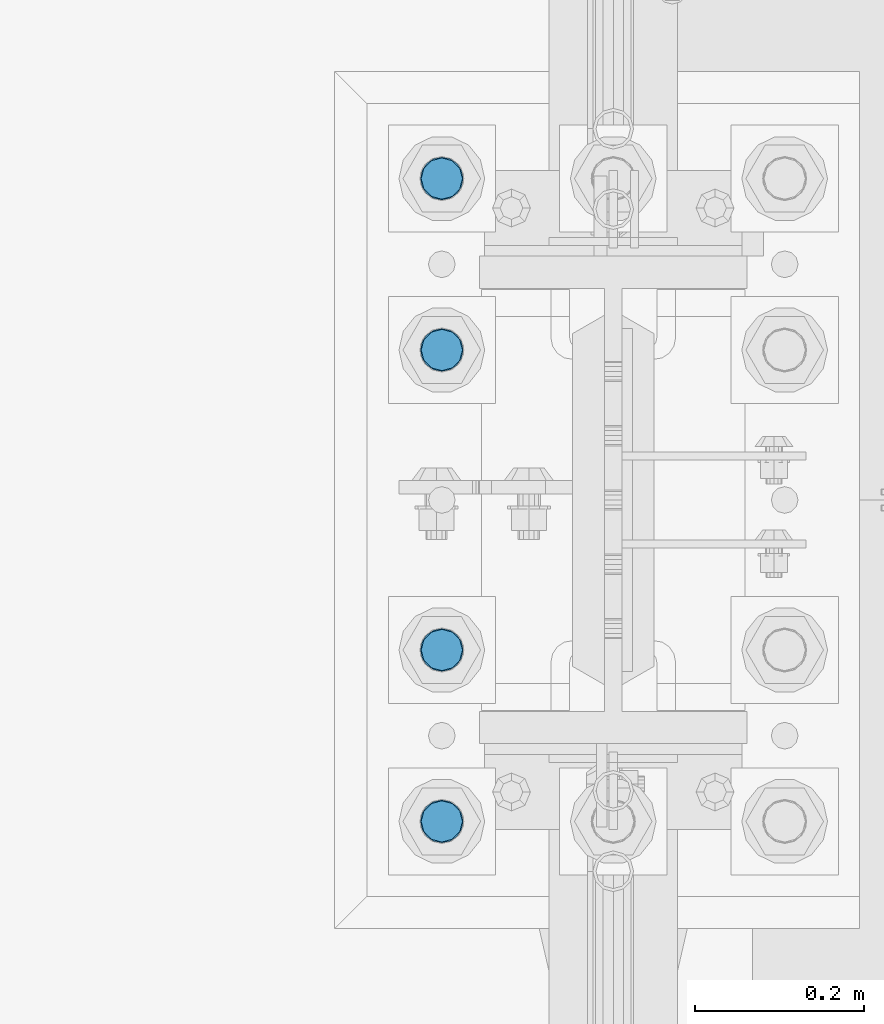
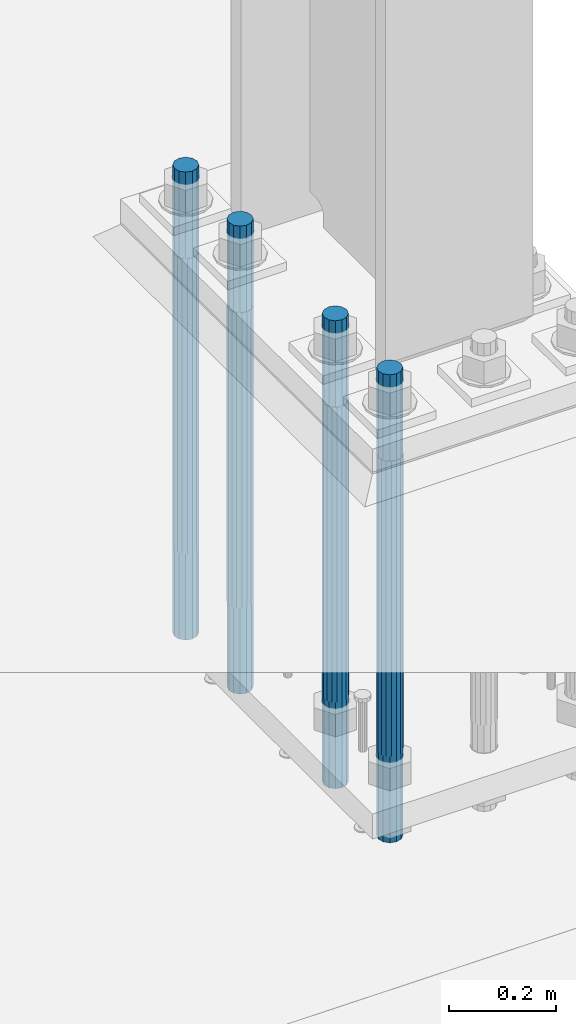
# One storey, part 738 of 1876: 4 columns, 1 element without a shape of its own.
"""IFC2X3 building model written with IfcOpenShell, lengths in millimetres."""

from ifc_helpers import new_model, si_unit, frame, origin_with_axes, place, context, subcontext, project, spatial, faceted_brep, material, type_object, element, aggregate, save


model = new_model("IFC2X3")

# Units and contexts
model_context = context("Model", 3, precision=1e-05, world=origin_with_axes())
body_context = subcontext(model_context, "Body", "Model", "MODEL_VIEW")
ifc_project = project(units=[si_unit("LENGTHUNIT", "METRE", prefix="MILLI"), si_unit("AREAUNIT", "SQUARE_METRE"), si_unit("VOLUMEUNIT", "CUBIC_METRE"), si_unit("MASSUNIT", "GRAM", prefix="KILO"), si_unit("TIMEUNIT", "SECOND"), si_unit("PLANEANGLEUNIT", "RADIAN"), si_unit("SOLIDANGLEUNIT", "STERADIAN"), si_unit("THERMODYNAMICTEMPERATUREUNIT", "DEGREE_CELSIUS"), si_unit("LUMINOUSINTENSITYUNIT", "LUMEN")], contexts=[model_context])

# Site, building, storey
site_placement = place(None, origin_with_axes())
site = spatial("IfcSite", under=ifc_project, at=site_placement, CompositionType="ELEMENT")
building_placement = place(site_placement, origin_with_axes())
building = spatial("IfcBuilding", under=site, at=building_placement, Name="Undefined", CompositionType="ELEMENT")
storey_placement = place(building_placement, origin_with_axes())
storey = spatial("IfcBuildingStorey", under=building, at=storey_placement, Name="Undefined", CompositionType="ELEMENT", Elevation=0.0)

# Assembly, columns
assembly_placement = place(storey_placement, origin_with_axes())
assembly = element("IfcElementAssembly", 1, at=assembly_placement, inside=storey, Name="TEMPLATE", AssemblyPlace="NOTDEFINED", PredefinedType="RIGID_FRAME")
ifc_material = material(Name="STEEL/F1554-GR.105")
column_type = type_object("IfcColumnType", PredefinedType="NOTDEFINED")
column_1_placement = place(assembly_placement, frame((7416.8, 7239.0, 0.0), z_axis=(0.0, -1.0, 0.0), x_axis=(0.0, 0.0, -1.0)))
column_1 = element("IfcColumn", 2, at=column_1_placement, type_object=column_type, material=ifc_material, Name="ANCHOR_BOLTS", context=body_context, shape_type="Brep", body=[
    faceted_brep([(-196.85, -21.217622392719, 12.25), (-196.85, -12.25, 21.2176223927188), (-196.85, 0.0, 24.5), (-196.85, 12.25, 21.2176223927188), (-196.85, 21.217622392719, 12.25), (-196.85, 24.5, 0.0), (-196.85, 21.217622392719, -12.25), (-196.85, 12.25, -21.2176223927188), (-196.85, 0.0, -24.5), (-196.85, -12.25, -21.2176223927188), (-196.85, -21.217622392719, -12.25), (-196.85, -24.5, 0.0), (0.0, 24.5, 0.0), (0.0, 21.217622392719, -12.25), (0.0, 12.25, -21.2176223927188), (0.0, 0.0, -24.5), (0.0, -12.25, -21.2176223927188), (0.0, -21.217622392719, -12.25), (0.0, -24.5, 0.0), (0.0, -21.217622392719, 12.25), (0.0, -12.25, 21.2176223927188), (0.0, 0.0, 24.5), (0.0, 12.25, 21.2176223927188), (0.0, 21.217622392719, 12.25), (0.0, -23.4665401257871, 9.7201591820733), (0.0, -17.9605122421381, 17.9605122421383), (0.0, -9.72015918207308, 23.4665401257867), (0.0, 0.0, 25.4000000000001), (0.0, 9.72015918207308, 23.4665401257867), (0.0, 17.9605122421381, 17.9605122421383), (0.0, 23.4665401257871, 9.7201591820733), (0.0, 25.3999996185339, 9.09494701772928e-13), (0.0, 23.4665401257871, -9.7201591820733), (0.0, 17.9605122421381, -17.9605122421383), (0.0, 9.72015918207308, -23.4665401257867), (0.0, 0.0, -25.4000000000001), (0.0, -9.72015918207308, -23.4665401257867), (0.0, -17.9605122421381, -17.9605122421383), (0.0, -23.4665401257871, -9.7201591820733), (0.0, -25.3999996185375, 0.0), (673.1, -25.3999999999996, 0.0), (673.1, -23.4665401257871, 9.7201591820733), (673.1, -17.9605122421381, 17.9605122421383), (673.1, -9.72015918207308, 23.4665401257867), (673.1, 0.0, 25.4000000000001), (673.1, 9.72015918207308, 23.4665401257867), (673.1, 17.9605122421381, 17.9605122421383), (673.1, 23.4665401257871, 9.7201591820733), (673.1, 25.3999999999996, 0.0), (673.1, 23.4665401257871, -9.7201591820733), (673.1, 17.9605122421381, -17.9605122421383), (673.1, 9.72015918207308, -23.4665401257867), (673.1, 0.0, -25.4000000000001), (673.1, -9.72015918207308, -23.4665401257867), (673.1, -17.9605122421381, -17.9605122421383), (673.1, -23.4665401257871, -9.7201591820733), (673.1, -12.25, 21.2176223927188), (673.1, 0.0, 24.5), (673.1, 12.25, 21.2176223927188), (673.1, 21.217622392719, 12.25), (673.1, 24.5, 0.0), (673.1, 21.217622392719, -12.25), (673.1, 12.25, -21.2176223927188), (673.1, 0.0, -24.5), (673.1, -12.25, -21.2176223927188), (673.1, -21.217622392719, -12.25), (673.1, -24.5, 0.0), (673.1, -21.217622392719, 12.25), (869.95, -12.25, -21.2176223927188), (869.95, 0.0, -24.5), (869.95, 12.25, -21.2176223927188), (869.95, 21.217622392719, -12.25), (869.95, 24.5, 0.0), (869.95, 21.217622392719, 12.25), (869.95, 12.25, 21.2176223927188), (869.95, 0.0, 24.5), (869.95, -12.25, 21.2176223927188), (869.95, -21.217622392719, 12.25), (869.95, -24.5, 0.0), (869.95, -21.217622392719, -12.25)], [[[0, 1, 2, 3, 4, 5, 6, 7, 8, 9, 10, 11]], [[6, 5, 12, 13]], [[7, 6, 13, 14]], [[8, 7, 14, 15]], [[9, 8, 15, 16]], [[10, 9, 16, 17]], [[11, 10, 17, 18]], [[0, 11, 18, 19]], [[1, 0, 19, 20]], [[2, 1, 20, 21]], [[3, 2, 21, 22]], [[4, 3, 22, 23]], [[5, 4, 23, 12]], [[24, 25, 26, 27, 28, 29, 30, 31, 32, 33, 34, 35, 36, 37, 38, 39], [22, 21, 20, 19, 18, 17, 16, 15, 14, 13, 12, 23]], [[24, 39, 40, 41]], [[25, 24, 41, 42]], [[26, 25, 42, 43]], [[27, 26, 43, 44]], [[28, 27, 44, 45]], [[29, 28, 45, 46]], [[30, 29, 46, 47]], [[31, 30, 47, 48]], [[32, 31, 48, 49]], [[33, 32, 49, 50]], [[34, 33, 50, 51]], [[35, 34, 51, 52]], [[36, 35, 52, 53]], [[37, 36, 53, 54]], [[38, 37, 54, 55]], [[39, 38, 55, 40]], [[54, 53, 52, 51, 50, 49, 48, 47, 46, 45, 44, 43, 42, 41, 40, 55], [56, 57, 58, 59, 60, 61, 62, 63, 64, 65, 66, 67]], [[68, 69, 70, 71, 72, 73, 74, 75, 76, 77, 78, 79]], [[76, 75, 57, 56]], [[77, 76, 56, 67]], [[78, 77, 67, 66]], [[79, 78, 66, 65]], [[68, 79, 65, 64]], [[69, 68, 64, 63]], [[70, 69, 63, 62]], [[71, 70, 62, 61]], [[72, 71, 61, 60]], [[73, 72, 60, 59]], [[74, 73, 59, 58]], [[75, 74, 58, 57]]]),
])
column_2_placement = place(assembly_placement, frame((7416.8, 7442.2, 0.0), z_axis=(0.0, -1.0, 0.0), x_axis=(0.0, 0.0, -1.0)))
column_2 = element("IfcColumn", 3, at=column_2_placement, type_object=column_type, material=ifc_material, Name="ANCHOR_BOLTS", context=body_context, shape_type="Brep", body=[
    faceted_brep([(-196.85, -21.217622392719, 12.25), (-196.85, -12.25, 21.2176223927188), (-196.85, 0.0, 24.5), (-196.85, 12.25, 21.2176223927188), (-196.85, 21.217622392719, 12.25), (-196.85, 24.5, 0.0), (-196.85, 21.217622392719, -12.25), (-196.85, 12.25, -21.2176223927188), (-196.85, 0.0, -24.5), (-196.85, -12.25, -21.2176223927188), (-196.85, -21.217622392719, -12.25), (-196.85, -24.5, 0.0), (0.0, 24.5, 0.0), (0.0, 21.217622392719, -12.25), (0.0, 12.25, -21.2176223927188), (0.0, 0.0, -24.5), (0.0, -12.25, -21.2176223927188), (0.0, -21.217622392719, -12.25), (0.0, -24.5, 0.0), (0.0, -21.217622392719, 12.25), (0.0, -12.25, 21.2176223927188), (0.0, 0.0, 24.5), (0.0, 12.25, 21.2176223927188), (0.0, 21.217622392719, 12.25), (0.0, -23.4665401257871, 9.7201591820733), (0.0, -17.9605122421381, 17.9605122421383), (0.0, -9.72015918207308, 23.4665401257867), (0.0, 0.0, 25.4000000000001), (0.0, 9.72015918207308, 23.4665401257867), (0.0, 17.9605122421381, 17.9605122421383), (0.0, 23.4665401257871, 9.7201591820733), (0.0, 25.3999996185339, 9.09494701772928e-13), (0.0, 23.4665401257871, -9.7201591820733), (0.0, 17.9605122421381, -17.9605122421383), (0.0, 9.72015918207308, -23.4665401257867), (0.0, 0.0, -25.4000000000001), (0.0, -9.72015918207308, -23.4665401257867), (0.0, -17.9605122421381, -17.9605122421383), (0.0, -23.4665401257871, -9.7201591820733), (0.0, -25.3999996185375, 0.0), (673.1, -25.3999999999996, 0.0), (673.1, -23.4665401257871, 9.7201591820733), (673.1, -17.9605122421381, 17.9605122421383), (673.1, -9.72015918207308, 23.4665401257867), (673.1, 0.0, 25.4000000000001), (673.1, 9.72015918207308, 23.4665401257867), (673.1, 17.9605122421381, 17.9605122421383), (673.1, 23.4665401257871, 9.7201591820733), (673.1, 25.3999999999996, 0.0), (673.1, 23.4665401257871, -9.7201591820733), (673.1, 17.9605122421381, -17.9605122421383), (673.1, 9.72015918207308, -23.4665401257867), (673.1, 0.0, -25.4000000000001), (673.1, -9.72015918207308, -23.4665401257867), (673.1, -17.9605122421381, -17.9605122421383), (673.1, -23.4665401257871, -9.7201591820733), (673.1, -12.25, 21.2176223927188), (673.1, 0.0, 24.5), (673.1, 12.25, 21.2176223927188), (673.1, 21.217622392719, 12.25), (673.1, 24.5, 0.0), (673.1, 21.217622392719, -12.25), (673.1, 12.25, -21.2176223927188), (673.1, 0.0, -24.5), (673.1, -12.25, -21.2176223927188), (673.1, -21.217622392719, -12.25), (673.1, -24.5, 0.0), (673.1, -21.217622392719, 12.25), (869.95, -12.25, -21.2176223927188), (869.95, 0.0, -24.5), (869.95, 12.25, -21.2176223927188), (869.95, 21.217622392719, -12.25), (869.95, 24.5, 0.0), (869.95, 21.217622392719, 12.25), (869.95, 12.25, 21.2176223927188), (869.95, 0.0, 24.5), (869.95, -12.25, 21.2176223927188), (869.95, -21.217622392719, 12.25), (869.95, -24.5, 0.0), (869.95, -21.217622392719, -12.25)], [[[0, 1, 2, 3, 4, 5, 6, 7, 8, 9, 10, 11]], [[6, 5, 12, 13]], [[7, 6, 13, 14]], [[8, 7, 14, 15]], [[9, 8, 15, 16]], [[10, 9, 16, 17]], [[11, 10, 17, 18]], [[0, 11, 18, 19]], [[1, 0, 19, 20]], [[2, 1, 20, 21]], [[3, 2, 21, 22]], [[4, 3, 22, 23]], [[5, 4, 23, 12]], [[24, 25, 26, 27, 28, 29, 30, 31, 32, 33, 34, 35, 36, 37, 38, 39], [22, 21, 20, 19, 18, 17, 16, 15, 14, 13, 12, 23]], [[24, 39, 40, 41]], [[25, 24, 41, 42]], [[26, 25, 42, 43]], [[27, 26, 43, 44]], [[28, 27, 44, 45]], [[29, 28, 45, 46]], [[30, 29, 46, 47]], [[31, 30, 47, 48]], [[32, 31, 48, 49]], [[33, 32, 49, 50]], [[34, 33, 50, 51]], [[35, 34, 51, 52]], [[36, 35, 52, 53]], [[37, 36, 53, 54]], [[38, 37, 54, 55]], [[39, 38, 55, 40]], [[54, 53, 52, 51, 50, 49, 48, 47, 46, 45, 44, 43, 42, 41, 40, 55], [56, 57, 58, 59, 60, 61, 62, 63, 64, 65, 66, 67]], [[68, 69, 70, 71, 72, 73, 74, 75, 76, 77, 78, 79]], [[76, 75, 57, 56]], [[77, 76, 56, 67]], [[78, 77, 67, 66]], [[79, 78, 66, 65]], [[68, 79, 65, 64]], [[69, 68, 64, 63]], [[70, 69, 63, 62]], [[71, 70, 62, 61]], [[72, 71, 61, 60]], [[73, 72, 60, 59]], [[74, 73, 59, 58]], [[75, 74, 58, 57]]]),
])
column_3_placement = place(assembly_placement, frame((7416.8, 7797.8, 0.0), z_axis=(0.0, -1.0, 0.0), x_axis=(0.0, 0.0, -1.0)))
column_3 = element("IfcColumn", 4, at=column_3_placement, type_object=column_type, material=ifc_material, Name="ANCHOR_BOLTS", context=body_context, shape_type="Brep", body=[
    faceted_brep([(-196.85, -21.217622392719, 12.25), (-196.85, -12.25, 21.2176223927188), (-196.85, 0.0, 24.5), (-196.85, 12.25, 21.2176223927188), (-196.85, 21.217622392719, 12.25), (-196.85, 24.5, 0.0), (-196.85, 21.217622392719, -12.25), (-196.85, 12.25, -21.2176223927188), (-196.85, 0.0, -24.5), (-196.85, -12.25, -21.2176223927188), (-196.85, -21.217622392719, -12.25), (-196.85, -24.5, 0.0), (0.0, 24.5, 0.0), (0.0, 21.217622392719, -12.25), (0.0, 12.25, -21.2176223927188), (0.0, 0.0, -24.5), (0.0, -12.25, -21.2176223927188), (0.0, -21.217622392719, -12.25), (0.0, -24.5, 0.0), (0.0, -21.217622392719, 12.25), (0.0, -12.25, 21.2176223927188), (0.0, 0.0, 24.5), (0.0, 12.25, 21.2176223927188), (0.0, 21.217622392719, 12.25), (0.0, -23.4665401257871, 9.7201591820733), (0.0, -17.9605122421381, 17.9605122421383), (0.0, -9.72015918207308, 23.4665401257867), (0.0, 0.0, 25.4000000000001), (0.0, 9.72015918207308, 23.4665401257867), (0.0, 17.9605122421381, 17.9605122421383), (0.0, 23.4665401257871, 9.7201591820733), (0.0, 25.3999996185339, 9.09494701772928e-13), (0.0, 23.4665401257871, -9.7201591820733), (0.0, 17.9605122421381, -17.9605122421383), (0.0, 9.72015918207308, -23.4665401257867), (0.0, 0.0, -25.4000000000001), (0.0, -9.72015918207308, -23.4665401257867), (0.0, -17.9605122421381, -17.9605122421383), (0.0, -23.4665401257871, -9.7201591820733), (0.0, -25.3999996185375, 0.0), (673.1, -25.3999999999996, 0.0), (673.1, -23.4665401257871, 9.7201591820733), (673.1, -17.9605122421381, 17.9605122421383), (673.1, -9.72015918207308, 23.4665401257867), (673.1, 0.0, 25.4000000000001), (673.1, 9.72015918207308, 23.4665401257867), (673.1, 17.9605122421381, 17.9605122421383), (673.1, 23.4665401257871, 9.7201591820733), (673.1, 25.3999999999996, 0.0), (673.1, 23.4665401257871, -9.7201591820733), (673.1, 17.9605122421381, -17.9605122421383), (673.1, 9.72015918207308, -23.4665401257867), (673.1, 0.0, -25.4000000000001), (673.1, -9.72015918207308, -23.4665401257867), (673.1, -17.9605122421381, -17.9605122421383), (673.1, -23.4665401257871, -9.7201591820733), (673.1, -12.25, 21.2176223927188), (673.1, 0.0, 24.5), (673.1, 12.25, 21.2176223927188), (673.1, 21.217622392719, 12.25), (673.1, 24.5, 0.0), (673.1, 21.217622392719, -12.25), (673.1, 12.25, -21.2176223927188), (673.1, 0.0, -24.5), (673.1, -12.25, -21.2176223927188), (673.1, -21.217622392719, -12.25), (673.1, -24.5, 0.0), (673.1, -21.217622392719, 12.25), (869.95, -12.25, -21.2176223927188), (869.95, 0.0, -24.5), (869.95, 12.25, -21.2176223927188), (869.95, 21.217622392719, -12.25), (869.95, 24.5, 0.0), (869.95, 21.217622392719, 12.25), (869.95, 12.25, 21.2176223927188), (869.95, 0.0, 24.5), (869.95, -12.25, 21.2176223927188), (869.95, -21.217622392719, 12.25), (869.95, -24.5, 0.0), (869.95, -21.217622392719, -12.25)], [[[0, 1, 2, 3, 4, 5, 6, 7, 8, 9, 10, 11]], [[6, 5, 12, 13]], [[7, 6, 13, 14]], [[8, 7, 14, 15]], [[9, 8, 15, 16]], [[10, 9, 16, 17]], [[11, 10, 17, 18]], [[0, 11, 18, 19]], [[1, 0, 19, 20]], [[2, 1, 20, 21]], [[3, 2, 21, 22]], [[4, 3, 22, 23]], [[5, 4, 23, 12]], [[24, 25, 26, 27, 28, 29, 30, 31, 32, 33, 34, 35, 36, 37, 38, 39], [22, 21, 20, 19, 18, 17, 16, 15, 14, 13, 12, 23]], [[24, 39, 40, 41]], [[25, 24, 41, 42]], [[26, 25, 42, 43]], [[27, 26, 43, 44]], [[28, 27, 44, 45]], [[29, 28, 45, 46]], [[30, 29, 46, 47]], [[31, 30, 47, 48]], [[32, 31, 48, 49]], [[33, 32, 49, 50]], [[34, 33, 50, 51]], [[35, 34, 51, 52]], [[36, 35, 52, 53]], [[37, 36, 53, 54]], [[38, 37, 54, 55]], [[39, 38, 55, 40]], [[54, 53, 52, 51, 50, 49, 48, 47, 46, 45, 44, 43, 42, 41, 40, 55], [56, 57, 58, 59, 60, 61, 62, 63, 64, 65, 66, 67]], [[68, 69, 70, 71, 72, 73, 74, 75, 76, 77, 78, 79]], [[76, 75, 57, 56]], [[77, 76, 56, 67]], [[78, 77, 67, 66]], [[79, 78, 66, 65]], [[68, 79, 65, 64]], [[69, 68, 64, 63]], [[70, 69, 63, 62]], [[71, 70, 62, 61]], [[72, 71, 61, 60]], [[73, 72, 60, 59]], [[74, 73, 59, 58]], [[75, 74, 58, 57]]]),
])
column_4_placement = place(assembly_placement, frame((7416.8, 8001.0, 0.0), z_axis=(0.0, -1.0, 0.0), x_axis=(0.0, 0.0, -1.0)))
column_4 = element("IfcColumn", 5, at=column_4_placement, type_object=column_type, material=ifc_material, Name="ANCHOR_BOLTS", context=body_context, shape_type="Brep", body=[
    faceted_brep([(-196.85, -21.217622392719, 12.25), (-196.85, -12.25, 21.2176223927188), (-196.85, 0.0, 24.5), (-196.85, 12.25, 21.2176223927188), (-196.85, 21.217622392719, 12.25), (-196.85, 24.5, 0.0), (-196.85, 21.217622392719, -12.25), (-196.85, 12.25, -21.2176223927188), (-196.85, 0.0, -24.5), (-196.85, -12.25, -21.2176223927188), (-196.85, -21.217622392719, -12.25), (-196.85, -24.5, 0.0), (0.0, 24.5, 0.0), (0.0, 21.217622392719, -12.25), (0.0, 12.25, -21.2176223927188), (0.0, 0.0, -24.5), (0.0, -12.25, -21.2176223927188), (0.0, -21.217622392719, -12.25), (0.0, -24.5, 0.0), (0.0, -21.217622392719, 12.25), (0.0, -12.25, 21.2176223927188), (0.0, 0.0, 24.5), (0.0, 12.25, 21.2176223927188), (0.0, 21.217622392719, 12.25), (0.0, -23.4665401257871, 9.7201591820733), (0.0, -17.9605122421381, 17.9605122421383), (0.0, -9.72015918207308, 23.4665401257867), (0.0, 0.0, 25.4000000000001), (0.0, 9.72015918207308, 23.4665401257867), (0.0, 17.9605122421381, 17.9605122421383), (0.0, 23.4665401257871, 9.7201591820733), (0.0, 25.3999996185339, 9.09494701772928e-13), (0.0, 23.4665401257871, -9.7201591820733), (0.0, 17.9605122421381, -17.9605122421383), (0.0, 9.72015918207308, -23.4665401257867), (0.0, 0.0, -25.4000000000001), (0.0, -9.72015918207308, -23.4665401257867), (0.0, -17.9605122421381, -17.9605122421383), (0.0, -23.4665401257871, -9.7201591820733), (0.0, -25.3999996185375, 0.0), (673.1, -25.3999999999996, 0.0), (673.1, -23.4665401257871, 9.7201591820733), (673.1, -17.9605122421381, 17.9605122421383), (673.1, -9.72015918207308, 23.4665401257867), (673.1, 0.0, 25.4000000000001), (673.1, 9.72015918207308, 23.4665401257867), (673.1, 17.9605122421381, 17.9605122421383), (673.1, 23.4665401257871, 9.7201591820733), (673.1, 25.3999999999996, 0.0), (673.1, 23.4665401257871, -9.7201591820733), (673.1, 17.9605122421381, -17.9605122421383), (673.1, 9.72015918207308, -23.4665401257867), (673.1, 0.0, -25.4000000000001), (673.1, -9.72015918207308, -23.4665401257867), (673.1, -17.9605122421381, -17.9605122421383), (673.1, -23.4665401257871, -9.7201591820733), (673.1, -12.25, 21.2176223927188), (673.1, 0.0, 24.5), (673.1, 12.25, 21.2176223927188), (673.1, 21.217622392719, 12.25), (673.1, 24.5, 0.0), (673.1, 21.217622392719, -12.25), (673.1, 12.25, -21.2176223927188), (673.1, 0.0, -24.5), (673.1, -12.25, -21.2176223927188), (673.1, -21.217622392719, -12.25), (673.1, -24.5, 0.0), (673.1, -21.217622392719, 12.25), (869.95, -12.25, -21.2176223927188), (869.95, 0.0, -24.5), (869.95, 12.25, -21.2176223927188), (869.95, 21.217622392719, -12.25), (869.95, 24.5, 0.0), (869.95, 21.217622392719, 12.25), (869.95, 12.25, 21.2176223927188), (869.95, 0.0, 24.5), (869.95, -12.25, 21.2176223927188), (869.95, -21.217622392719, 12.25), (869.95, -24.5, 0.0), (869.95, -21.217622392719, -12.25)], [[[0, 1, 2, 3, 4, 5, 6, 7, 8, 9, 10, 11]], [[6, 5, 12, 13]], [[7, 6, 13, 14]], [[8, 7, 14, 15]], [[9, 8, 15, 16]], [[10, 9, 16, 17]], [[11, 10, 17, 18]], [[0, 11, 18, 19]], [[1, 0, 19, 20]], [[2, 1, 20, 21]], [[3, 2, 21, 22]], [[4, 3, 22, 23]], [[5, 4, 23, 12]], [[24, 25, 26, 27, 28, 29, 30, 31, 32, 33, 34, 35, 36, 37, 38, 39], [22, 21, 20, 19, 18, 17, 16, 15, 14, 13, 12, 23]], [[24, 39, 40, 41]], [[25, 24, 41, 42]], [[26, 25, 42, 43]], [[27, 26, 43, 44]], [[28, 27, 44, 45]], [[29, 28, 45, 46]], [[30, 29, 46, 47]], [[31, 30, 47, 48]], [[32, 31, 48, 49]], [[33, 32, 49, 50]], [[34, 33, 50, 51]], [[35, 34, 51, 52]], [[36, 35, 52, 53]], [[37, 36, 53, 54]], [[38, 37, 54, 55]], [[39, 38, 55, 40]], [[54, 53, 52, 51, 50, 49, 48, 47, 46, 45, 44, 43, 42, 41, 40, 55], [56, 57, 58, 59, 60, 61, 62, 63, 64, 65, 66, 67]], [[68, 69, 70, 71, 72, 73, 74, 75, 76, 77, 78, 79]], [[76, 75, 57, 56]], [[77, 76, 56, 67]], [[78, 77, 67, 66]], [[79, 78, 66, 65]], [[68, 79, 65, 64]], [[69, 68, 64, 63]], [[70, 69, 63, 62]], [[71, 70, 62, 61]], [[72, 71, 61, 60]], [[73, 72, 60, 59]], [[74, 73, 59, 58]], [[75, 74, 58, 57]]]),
])
aggregate(assembly, [column_1, column_2, column_3, column_4])

save(model, "model.ifc")
